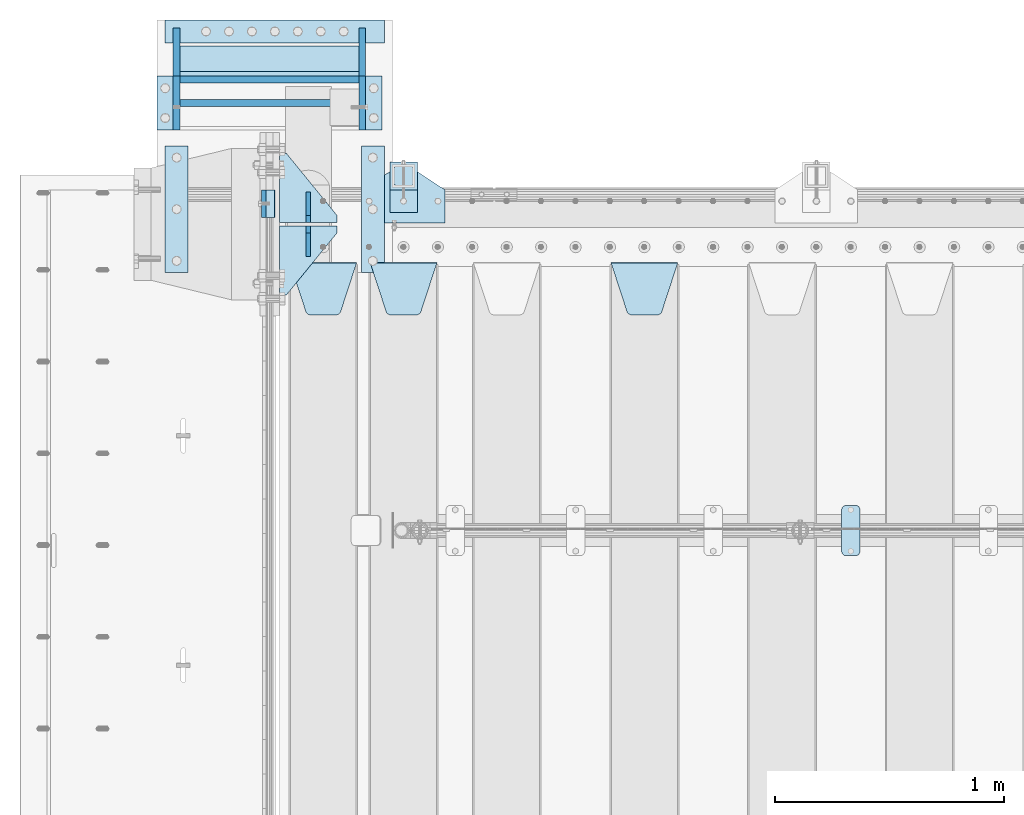
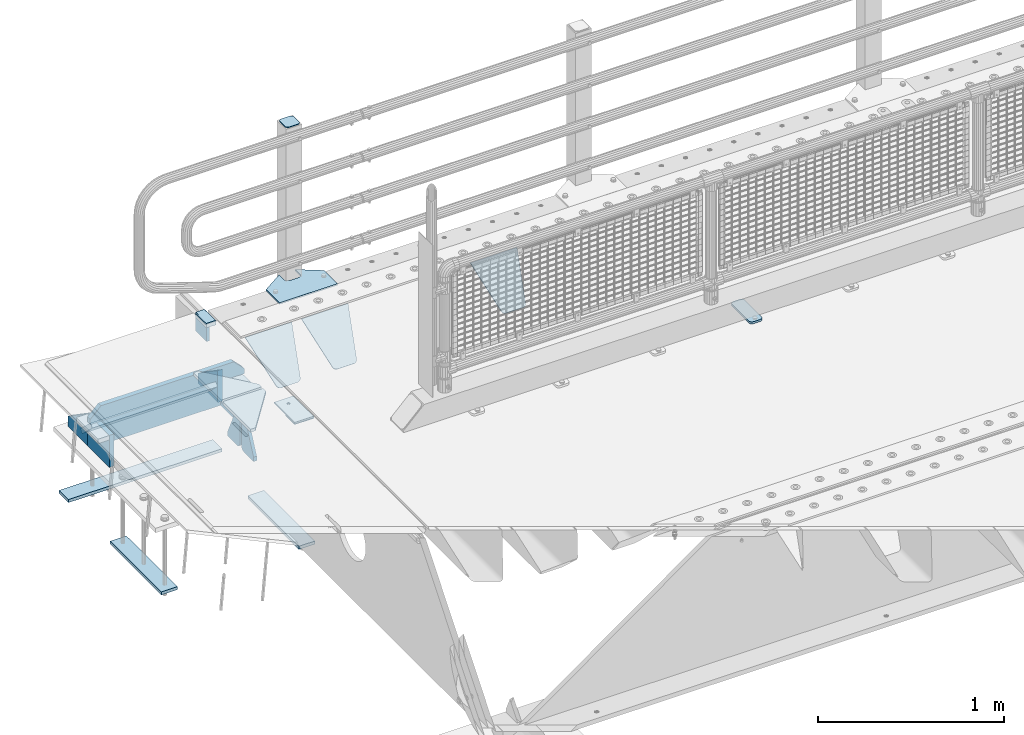
# One storey, part 159 of 193: 26 plates.
"""IFC2X3 building model written with IfcOpenShell, lengths in millimetres."""

from ifc_helpers import new_model, si_unit, frame, origin_with_axes, place, context, subcontext, project, spatial, faceted_brep, material, type_object, element, save


model = new_model("IFC2X3")

# Units and contexts
model_context = context("Model", 3, precision=1e-05, world=origin_with_axes())
body_context = subcontext(model_context, "Body", "Model", "MODEL_VIEW")
ifc_project = project(units=[si_unit("LENGTHUNIT", "METRE", prefix="MILLI"), si_unit("AREAUNIT", "SQUARE_METRE"), si_unit("VOLUMEUNIT", "CUBIC_METRE"), si_unit("MASSUNIT", "GRAM", prefix="KILO"), si_unit("TIMEUNIT", "SECOND"), si_unit("PLANEANGLEUNIT", "RADIAN"), si_unit("SOLIDANGLEUNIT", "STERADIAN"), si_unit("THERMODYNAMICTEMPERATUREUNIT", "DEGREE_CELSIUS"), si_unit("LUMINOUSINTENSITYUNIT", "LUMEN")], contexts=[model_context])

# Site, building, storey
site_placement = place(None, origin_with_axes())
site = spatial("IfcSite", under=ifc_project, at=site_placement, CompositionType="ELEMENT")
building_placement = place(site_placement, origin_with_axes())
building = spatial("IfcBuilding", under=site, at=building_placement, Name="Standard", CompositionType="ELEMENT")
storey_placement = place(building_placement, origin_with_axes())
storey = spatial("IfcBuildingStorey", under=building, at=storey_placement, Name="Undefined", CompositionType="ELEMENT", Elevation=0.0)

# Plates
ifc_material_1 = material()
plate_type_1 = type_object("IfcPlateType", PredefinedType="NOTDEFINED")
plate_1_placement = place(storey_placement, frame((-42460.0, 30090.0, -16.0000571414005), z_axis=(-1.0, 0.0, 0.0), x_axis=(0.0, 0.0, 1.0)))
element("IfcPlate", 1, at=plate_1_placement, inside=storey, type_object=plate_type_1, material=ifc_material_1, context=body_context, shape_type="Brep", body=[
    faceted_brep([(3.5527136788005e-15, -60.0, 0.0), (2.49929144047201e-09, -60.0, 60.0), (2.49929144047201e-09, 60.0000000000036, 60.0), (0.0, 60.0, -7.27595761418343e-12), (25.0146748218828, -60.0, 60.0), (25.0146748218828, 60.0, 60.0), (26.5597449794466, -60.0, 59.7552873949098), (26.5597449794466, 60.0000000000036, 59.7552873949098), (27.9535758796897, -59.9999999999964, 59.0451032832789), (27.9535758796897, 60.0000000000036, 59.0451032832789), (29.0597323263517, -60.0, 57.9389640667287), (29.0597323263517, 60.0, 57.9389640667287), (29.7699381491534, -60.0, 56.5451442289705), (29.7699381491534, 60.0, 56.5451442289705), (30.0146748212763, -60.0, 55.0000778834001), (30.0146748212763, 60.0, 55.0000778834001), (30.0154536553013, -59.9999999999964, 5.00007788340736), (30.0154536553013, 60.0000000000036, 5.00007788340736), (29.7707554908505, -60.0, 3.45497428546514), (29.7707554908505, 60.0, 3.45497428546514), (29.0605660948355, -60.0, 2.06111154406972), (29.0605660948355, 60.0, 2.06111154406972), (27.9544051209123, -59.9999999999964, 0.954933339693525), (27.9544051209123, 60.0000000000036, 0.954933339693525), (26.5605534420796, -60.0, 0.244722232011554), (26.5605534420796, 60.0, 0.244722232011554), (25.0154536559091, -60.0, 7.27595761418343e-12), (25.0154536559091, 60.0, 7.27595761418343e-12)], [[[0, 1, 2, 3]], [[1, 4, 5, 2]], [[4, 6, 7, 5]], [[6, 8, 9, 7]], [[8, 10, 11, 9]], [[10, 12, 13, 11]], [[12, 14, 15, 13]], [[14, 16, 17, 15]], [[16, 18, 19, 17]], [[18, 20, 21, 19]], [[20, 22, 23, 21]], [[22, 24, 25, 23]], [[24, 26, 27, 25]], [[26, 0, 3, 27]], [[5, 7, 9, 11, 13, 15, 17, 19, 21, 23, 25, 27, 3, 2]], [[26, 24, 22, 20, 18, 16, 14, 12, 10, 8, 6, 4, 1, 0]]]),
])
ifc_material_2 = material(Name="STEEL/S355N")
plate_type_2 = type_object("IfcPlateType", PredefinedType="NOTDEFINED")
plate_2_placement = place(storey_placement, frame((-42510.0, 30150.0000855345, -105.984391680281), z_axis=(0.0, -1.0, 0.0), x_axis=(0.0, 0.0, 1.0)))
element("IfcPlate", 2, at=plate_2_placement, inside=storey, type_object=plate_type_2, material=ifc_material_2, context=body_context, shape_type="Brep", body=[
    faceted_brep([(0.0, -10.0, 0.0), (5.70725632087488e-07, -10.0, 120.0), (5.70725632087488e-07, 10.0, 120.0), (0.0, 10.0, 0.0), (89.9845046997066, -10.0, 120.000000000004), (89.9845046997066, 10.0, 120.000000000004), (89.9843902587891, -10.0, 6.54836185276508e-11), (89.9843902587891, 10.0, 6.54836185276508e-11)], [[[0, 1, 2, 3]], [[1, 4, 5, 2]], [[4, 6, 7, 5]], [[6, 0, 3, 7]], [[5, 7, 3, 2]], [[6, 4, 1, 0]]]),
])
plate_type_3 = type_object("IfcPlateType", PredefinedType="NOTDEFINED")
plate_3_placement = place(storey_placement, frame((-40995.0, 29831.767766956, -1.76776695296758), z_axis=(0.0, -0.707106781186547, -0.707106781186548), x_axis=(1.0, 0.0, 0.0)))
element("IfcPlate", 3, at=plate_3_placement, inside=storey, type_object=plate_type_3, material=ifc_material_2, context=body_context, shape_type="Brep", body=[
    faceted_brep([(0.0, -2.5, 0.0), (69.345504679477, -2.50000000000364, 300.171731424831), (69.345504679477, 2.49999999999636, 300.171731424831), (0.0, 2.5, 0.0), (70.9274061199576, -2.50000000000364, 304.897442415397), (70.9274061199576, 2.49999999999636, 304.897442415397), (73.3818627772307, -2.50000000000364, 309.234538108529), (73.3818627772307, 2.49999999999636, 309.234538108529), (76.6187032999551, -2.50000000000728, 313.023683126103), (76.6187032999551, 2.49999999999636, 313.023683126103), (80.5190132704993, -2.50000000000364, 316.125672595372), (80.5190132704993, 2.49999999999636, 316.125672595368), (84.9395038596849, -2.50000000000364, 318.426546230472), (84.9395038596849, 2.49999999999636, 318.426546230476), (89.7177759439219, -2.50000000000364, 319.841774983273), (89.7177759439219, 2.49999999999636, 319.841774983277), (94.678286292652, -2.50000000000364, 320.319366455074), (94.678286292652, 2.49999999999636, 320.319366455074), (195.321713707348, -2.50000000000364, 320.319366455074), (195.321713707348, 2.49999999999636, 320.319366455074), (200.282224056078, -2.50000000000364, 319.841774983273), (200.282224056078, 2.49999999999636, 319.841774983277), (205.060496140315, -2.50000000000364, 318.426546230472), (205.060496140315, 2.49999999999636, 318.426546230472), (209.480986729501, -2.50000000000364, 316.125672595372), (209.480986729501, 2.49999999999636, 316.125672595368), (213.381296700045, -2.50000000000728, 313.023683126103), (213.381296700045, 2.49999999999272, 313.023683126103), (216.618137222769, -2.50000000000364, 309.234538108525), (216.618137222769, 2.49999999999636, 309.234538108522), (219.072593880042, -2.50000000000364, 304.897442415397), (219.072593880042, 2.49999999999636, 304.897442415397), (220.654495320523, -2.50000000000364, 300.171731424831), (220.654495320523, 2.49999999999636, 300.171731424831), (290.0, -2.50000000000364, 0.0), (290.0, 2.49999999999636, 0.0)], [[[0, 1, 2, 3]], [[1, 4, 5, 2]], [[4, 6, 7, 5]], [[6, 8, 9, 7]], [[8, 10, 11, 9]], [[10, 12, 13, 11]], [[12, 14, 15, 13]], [[14, 16, 17, 15]], [[16, 18, 19, 17]], [[18, 20, 21, 19]], [[20, 22, 23, 21]], [[22, 24, 25, 23]], [[24, 26, 27, 25]], [[26, 28, 29, 27]], [[28, 30, 31, 29]], [[30, 32, 33, 31]], [[32, 34, 35, 33]], [[34, 0, 3, 35]], [[5, 7, 9, 11, 13, 15, 17, 19, 21, 23, 25, 27, 29, 31, 33, 35, 3, 2]], [[34, 32, 30, 28, 26, 24, 22, 20, 18, 16, 14, 12, 10, 8, 6, 4, 1, 0]]]),
])
plate_4_placement = place(storey_placement, frame((-42045.0, 29831.767766956, -1.76776695296758), z_axis=(0.0, -0.707106781186547, -0.707106781186548), x_axis=(1.0, 0.0, 0.0)))
element("IfcPlate", 4, at=plate_4_placement, inside=storey, type_object=plate_type_3, material=ifc_material_2, context=body_context, shape_type="Brep", body=[
    faceted_brep([(0.0, -2.5, 0.0), (69.345504679477, -2.50000000000364, 300.171731424831), (69.345504679477, 2.49999999999636, 300.171731424831), (0.0, 2.5, 0.0), (70.9274061199576, -2.50000000000364, 304.897442415397), (70.9274061199576, 2.49999999999636, 304.897442415397), (73.3818627772307, -2.50000000000364, 309.234538108529), (73.3818627772307, 2.49999999999636, 309.234538108529), (76.6187032999551, -2.50000000000728, 313.023683126103), (76.6187032999551, 2.49999999999636, 313.023683126103), (80.5190132704993, -2.50000000000364, 316.125672595372), (80.5190132704993, 2.49999999999636, 316.125672595368), (84.9395038596849, -2.50000000000364, 318.426546230472), (84.9395038596849, 2.49999999999636, 318.426546230476), (89.7177759439219, -2.50000000000364, 319.841774983273), (89.7177759439219, 2.49999999999636, 319.841774983277), (94.678286292652, -2.50000000000364, 320.319366455074), (94.678286292652, 2.49999999999636, 320.319366455074), (195.321713707348, -2.50000000000364, 320.319366455074), (195.321713707348, 2.49999999999636, 320.319366455074), (200.282224056078, -2.50000000000364, 319.841774983273), (200.282224056078, 2.49999999999636, 319.841774983277), (205.060496140315, -2.50000000000364, 318.426546230472), (205.060496140315, 2.49999999999636, 318.426546230472), (209.480986729501, -2.50000000000364, 316.125672595372), (209.480986729501, 2.49999999999636, 316.125672595368), (213.381296700045, -2.50000000000728, 313.023683126103), (213.381296700045, 2.49999999999272, 313.023683126103), (216.618137222769, -2.50000000000364, 309.234538108525), (216.618137222769, 2.49999999999636, 309.234538108522), (219.072593880042, -2.50000000000364, 304.897442415397), (219.072593880042, 2.49999999999636, 304.897442415397), (220.654495320523, -2.50000000000364, 300.171731424831), (220.654495320523, 2.49999999999636, 300.171731424831), (290.0, -2.50000000000364, 0.0), (290.0, 2.49999999999636, 0.0)], [[[0, 1, 2, 3]], [[1, 4, 5, 2]], [[4, 6, 7, 5]], [[6, 8, 9, 7]], [[8, 10, 11, 9]], [[10, 12, 13, 11]], [[12, 14, 15, 13]], [[14, 16, 17, 15]], [[16, 18, 19, 17]], [[18, 20, 21, 19]], [[20, 22, 23, 21]], [[22, 24, 25, 23]], [[24, 26, 27, 25]], [[26, 28, 29, 27]], [[28, 30, 31, 29]], [[30, 32, 33, 31]], [[32, 34, 35, 33]], [[34, 0, 3, 35]], [[5, 7, 9, 11, 13, 15, 17, 19, 21, 23, 25, 27, 29, 31, 33, 35, 3, 2]], [[34, 32, 30, 28, 26, 24, 22, 20, 18, 16, 14, 12, 10, 8, 6, 4, 1, 0]]]),
])
plate_5_placement = place(storey_placement, frame((-42395.0, 29831.767766956, -1.76776695296758), z_axis=(0.0, -0.707106781186547, -0.707106781186548), x_axis=(1.0, 0.0, 0.0)))
element("IfcPlate", 5, at=plate_5_placement, inside=storey, type_object=plate_type_3, material=ifc_material_2, context=body_context, shape_type="Brep", body=[
    faceted_brep([(0.0, -2.5, 0.0), (69.345504679477, -2.50000000000364, 300.171731424831), (69.345504679477, 2.49999999999636, 300.171731424831), (0.0, 2.5, 0.0), (70.9274061199576, -2.50000000000364, 304.897442415397), (70.9274061199576, 2.49999999999636, 304.897442415397), (73.3818627772307, -2.50000000000364, 309.234538108529), (73.3818627772307, 2.49999999999636, 309.234538108529), (76.6187032999551, -2.50000000000728, 313.023683126103), (76.6187032999551, 2.49999999999636, 313.023683126103), (80.5190132704993, -2.50000000000364, 316.125672595372), (80.5190132704993, 2.49999999999636, 316.125672595368), (84.9395038596849, -2.50000000000364, 318.426546230472), (84.9395038596849, 2.49999999999636, 318.426546230476), (89.7177759439219, -2.50000000000364, 319.841774983273), (89.7177759439219, 2.49999999999636, 319.841774983277), (94.678286292652, -2.50000000000364, 320.319366455074), (94.678286292652, 2.49999999999636, 320.319366455074), (195.321713707348, -2.50000000000364, 320.319366455074), (195.321713707348, 2.49999999999636, 320.319366455074), (200.282224056078, -2.50000000000364, 319.841774983273), (200.282224056078, 2.49999999999636, 319.841774983277), (205.060496140315, -2.50000000000364, 318.426546230472), (205.060496140315, 2.49999999999636, 318.426546230472), (209.480986729501, -2.50000000000364, 316.125672595372), (209.480986729501, 2.49999999999636, 316.125672595368), (213.381296700045, -2.50000000000728, 313.023683126103), (213.381296700045, 2.49999999999272, 313.023683126103), (216.618137222769, -2.50000000000364, 309.234538108525), (216.618137222769, 2.49999999999636, 309.234538108522), (219.072593880042, -2.50000000000364, 304.897442415397), (219.072593880042, 2.49999999999636, 304.897442415397), (220.654495320523, -2.50000000000364, 300.171731424831), (220.654495320523, 2.49999999999636, 300.171731424831), (290.0, -2.50000000000364, 0.0), (290.0, 2.49999999999636, 0.0)], [[[0, 1, 2, 3]], [[1, 4, 5, 2]], [[4, 6, 7, 5]], [[6, 8, 9, 7]], [[8, 10, 11, 9]], [[10, 12, 13, 11]], [[12, 14, 15, 13]], [[14, 16, 17, 15]], [[16, 18, 19, 17]], [[18, 20, 21, 19]], [[20, 22, 23, 21]], [[22, 24, 25, 23]], [[24, 26, 27, 25]], [[26, 28, 29, 27]], [[28, 30, 31, 29]], [[30, 32, 33, 31]], [[32, 34, 35, 33]], [[34, 0, 3, 35]], [[5, 7, 9, 11, 13, 15, 17, 19, 21, 23, 25, 27, 29, 31, 33, 35, 3, 2]], [[34, 32, 30, 28, 26, 24, 22, 20, 18, 16, 14, 12, 10, 8, 6, 4, 1, 0]]]),
])
plate_type_4 = type_object("IfcPlateType", PredefinedType="NOTDEFINED")
for number, where, z_axis, x_axis in (
    (6, (-42190.0, 30008.0, -515.0), (0.0, 1.0, 0.0), (-1.0, 0.0, 0.0)),
    (7, (-42190.0, 29992.0, -515.0), (0.0, -1.0, 0.0), (-1.0, 0.0, 0.0)),
):
    element("IfcPlate", number, at=place(storey_placement, frame(where, z_axis=z_axis, x_axis=x_axis)), inside=storey, type_object=plate_type_4, material=ifc_material_2, context=body_context, shape_type="Brep", body=[
        faceted_brep([(0.0, -10.0, 0.0), (0.0, -10.0, 30.0), (0.0, 10.0, 30.0), (0.0, 10.0, 0.0), (220.0, -10.0, 300.0), (220.0, 10.0, 300.0), (250.0, -10.0, 300.0), (250.0, 10.0, 300.0), (250.0, -10.0, 0.0), (250.0, 10.0, 0.0)], [[[0, 1, 2, 3]], [[1, 4, 5, 2]], [[4, 6, 7, 5]], [[6, 8, 9, 7]], [[8, 0, 3, 9]], [[5, 7, 9, 3, 2]], [[8, 6, 4, 1, 0]]]),
    ])
plate_type_5 = type_object("IfcPlateType", PredefinedType="NOTDEFINED")
for number, where, z_axis, x_axis in (
    (8, (-42315.0, 29860.0, -860.0), (0.0, 0.0, 1.0), (0.0, 1.0, 0.0)),
    (9, (-42315.0, 30140.0, -860.0), (0.0, 0.0, 1.0), (0.0, -1.0, 0.0)),
):
    element("IfcPlate", number, at=place(storey_placement, frame(where, z_axis=z_axis, x_axis=x_axis)), inside=storey, type_object=plate_type_5, material=ifc_material_2, context=body_context, shape_type="Brep", body=[
        faceted_brep([(0.0, -10.0, 0.0), (0.0, -10.0, 30.0), (0.0, 10.0, 30.0), (0.0, 10.0, 0.0), (102.0, -10.0, 250.0), (102.0, 10.0, 250.0), (132.0, -10.0, 250.0), (132.0, 10.0, 250.0), (132.0, -10.0, 30.0), (132.0, 10.0, 30.0), (131.544232590368, -10.0, 24.790554669992), (131.544232590368, 10.0, 24.790554669992), (130.190778623579, -10.0, 19.7393957002299), (130.190778623579, 10.0, 19.7393957002299), (127.980762113533, -10.0, 15.0), (127.980762113533, 10.0, 15.0), (124.98133329357, -10.0, 10.7163717094038), (124.98133329357, 10.0, 10.7163717094038), (121.283628290596, -10.0, 7.01866670643062), (121.283628290596, 10.0, 7.01866670643062), (117.0, -10.0, 4.01923788646684), (117.0, 10.0, 4.01923788646684), (112.260604299769, -10.0, 1.80922137642278), (112.260604299769, 10.0, 1.80922137642278), (107.209445330009, -10.0, 0.455767409633722), (107.209445330009, 10.0, 0.455767409633722), (102.0, -10.0, 0.0), (102.0, 10.0, 0.0)], [[[0, 1, 2, 3]], [[1, 4, 5, 2]], [[4, 6, 7, 5]], [[6, 8, 9, 7]], [[8, 10, 11, 9]], [[10, 12, 13, 11]], [[12, 14, 15, 13]], [[14, 16, 17, 15]], [[16, 18, 19, 17]], [[18, 20, 21, 19]], [[20, 22, 23, 21]], [[22, 24, 25, 23]], [[24, 26, 27, 25]], [[26, 0, 3, 27]], [[5, 7, 9, 11, 13, 15, 17, 19, 21, 23, 25, 27, 3, 2]], [[26, 24, 22, 20, 18, 16, 14, 12, 10, 8, 6, 4, 1, 0]]]),
    ])
ifc_material_3 = material(Name="STEEL/S355J2")
plate_type_6 = type_object("IfcPlateType", PredefinedType="NOTDEFINED")
plate_6_placement = place(storey_placement, frame((-42080.0, 30005.0, 5.00000000004911), z_axis=(0.0, 1.0, 0.0), x_axis=(1.0, 0.0, 0.0)))
element("IfcPlate", 10, at=plate_6_placement, inside=storey, type_object=plate_type_6, material=ifc_material_3, context=body_context, shape_type="Brep", body=[
    faceted_brep([(0.0, -5.0, 0.0), (2.31396552408114e-06, -5.0, 145.0), (2.31396552408114e-06, 5.0, 145.0), (0.0, 5.0, 0.0), (130.0, -5.0, 230.0), (130.0, 5.0, 230.0), (130.0, -5.0, 180.0), (130.0, 5.0, 180.0), (130.48036798992, -5.0, 175.122741949595), (130.48036798992, 5.0, 175.122741949595), (131.903011687216, -5.0, 170.432914190871), (131.903011687216, 5.0, 170.432914190871), (134.213259692435, -5.0, 166.110744174512), (134.213259692435, 5.0, 166.110744174512), (137.322330470335, -5.0, 162.322330470335), (137.322330470335, 5.0, 162.322330470335), (141.110744174512, -5.0, 159.213259692435), (141.110744174512, 5.0, 159.213259692435), (145.432914190871, -5.0, 156.903011687216), (145.432914190871, 5.0, 156.903011687216), (150.122741949595, -5.0, 155.48036798992), (150.122741949595, 5.0, 155.48036798992), (155.0, -5.0, 155.0), (155.0, 5.0, 155.0), (205.0, -5.0, 155.0), (205.0, 5.0, 155.0), (209.877258050405, -5.0, 155.48036798992), (209.877258050405, 5.0, 155.48036798992), (214.567085809129, -5.0, 156.903011687216), (214.567085809129, 5.0, 156.903011687216), (218.889255825488, -5.0, 159.213259692435), (218.889255825488, 5.0, 159.213259692435), (222.677669529665, -5.0, 162.322330470335), (222.677669529665, 5.0, 162.322330470335), (225.786740307565, -5.0, 166.110744174512), (225.786740307565, 5.0, 166.110744174512), (228.096988312784, -5.0, 170.432914190871), (228.096988312784, 5.0, 170.432914190871), (229.51963201008, -5.0, 175.122741949595), (229.51963201008, 5.0, 175.122741949595), (230.0, -5.0, 180.0), (230.0, 5.0, 180.0), (230.0, -5.0, 230.0), (230.0, 5.0, 230.0), (360.0, -5.0, 145.0), (360.0, 5.0, 145.0), (360.0, -5.0, -7.27595761418343e-12), (360.0, 5.0, -7.27595761418343e-12)], [[[0, 1, 2, 3]], [[1, 4, 5, 2]], [[4, 6, 7, 5]], [[6, 8, 9, 7]], [[8, 10, 11, 9]], [[10, 12, 13, 11]], [[12, 14, 15, 13]], [[14, 16, 17, 15]], [[16, 18, 19, 17]], [[18, 20, 21, 19]], [[20, 22, 23, 21]], [[22, 24, 25, 23]], [[24, 26, 27, 25]], [[26, 28, 29, 27]], [[28, 30, 31, 29]], [[30, 32, 33, 31]], [[32, 34, 35, 33]], [[34, 36, 37, 35]], [[36, 38, 39, 37]], [[38, 40, 41, 39]], [[40, 42, 43, 41]], [[42, 44, 45, 43]], [[44, 46, 47, 45]], [[46, 0, 3, 47]], [[5, 7, 9, 11, 13, 15, 17, 19, 21, 23, 25, 27, 29, 31, 33, 35, 37, 39, 41, 43, 45, 47, 3, 2]], [[46, 44, 42, 40, 38, 36, 34, 32, 30, 28, 26, 24, 22, 20, 18, 16, 14, 12, 10, 8, 6, 4, 1, 0]]]),
])
plate_type_7 = type_object("IfcPlateType", PredefinedType="NOTDEFINED")
plate_7_placement = place(storey_placement, frame((-41959.9999999999, 30050.0000000002, -850.000000000002), z_axis=(0.0, 1.0, 0.0), x_axis=(1.0, 0.0, 0.0)))
element("IfcPlate", 11, at=plate_7_placement, inside=storey, type_object=plate_type_7, material=ifc_material_3, context=body_context, shape_type="Brep", body=[
    faceted_brep([(66.3639610305399, -5.0, 163.636038969111), (66.3639610305399, 5.0, 163.636038969111), (59.9999999998618, 5.0, 160.999999999789), (59.9999999998618, -5.0, 160.999999999789), (53.6360389691836, 5.0, 163.636038969111), (53.6360389691836, -5.0, 163.636038969111), (50.9999999998618, 5.0, 169.999999999789), (50.9999999998618, -5.0, 169.999999999789), (53.6360389691836, 5.0, 176.363961030467), (53.6360389691836, -5.0, 176.363961030467), (59.9999999998618, 5.0, 178.999999999789), (59.9999999998618, -5.0, 178.999999999789), (66.3639610305399, 5.0, 176.363961030467), (66.3639610305399, -5.0, 176.363961030467), (68.9999999998618, 5.0, 169.999999999789), (68.9999999998618, -5.0, 169.999999999789), (120.0, -5.0, 0.0), (120.0, -5.0, 220.0), (0.0, -5.0, 220.0), (0.0, -5.0, 0.0), (0.0, 5.0, 0.0), (120.0, 5.0, 0.0), (120.0, 5.0, 220.0), (0.0, 5.0, 220.0)], [[[0, 1, 2, 3]], [[3, 2, 4, 5]], [[5, 4, 6, 7]], [[7, 6, 8, 9]], [[9, 8, 10, 11]], [[11, 10, 12, 13]], [[13, 12, 14, 15]], [[15, 14, 1, 0]], [[16, 17, 18, 19], [3, 5, 7, 9, 11, 13, 15, 0]], [[16, 19, 20, 21]], [[17, 16, 21, 22]], [[18, 17, 22, 23]], [[19, 18, 23, 20]], [[22, 21, 20, 23], [10, 8, 6, 4, 2, 1, 14, 12]]]),
])
plate_type_8 = type_object("IfcPlateType", PredefinedType="NOTDEFINED")
plate_8_placement = place(storey_placement, frame((-41855.9999999999, 30166.0000000002, 1012.50000000001), z_axis=(0.0, 1.0, 0.0), x_axis=(-1.0, 0.0, 0.0)))
element("IfcPlate", 12, at=plate_8_placement, inside=storey, type_object=plate_type_8, material=ifc_material_3, context=body_context, shape_type="Brep", body=[
    faceted_brep([(0.0, -2.5, 19.0), (0.0, -2.5, 69.0), (0.0, 2.5, 69.0), (0.0, 2.5, 19.0), (0.476369668544066, -2.5, 73.2278977451715), (0.476369668544066, 2.5, 73.2278977451715), (1.88159150985302, -2.5, 77.2437910432345), (1.88159150985302, 2.5, 77.2437910432345), (4.14520183310742, -2.5, 80.8463062353148), (4.14520183310742, 2.5, 80.8463062353148), (7.15369376468516, -2.5, 83.8547981668926), (7.15369376468516, 2.5, 83.8547981668926), (10.7562089567655, -2.5, 86.118408490147), (10.7562089567655, 2.5, 86.118408490147), (14.7721022548285, -2.5, 87.5236303314559), (14.7721022548285, 2.5, 87.5236303314559), (19.0, -2.5, 88.0), (19.0, 2.5, 88.0), (69.0, -2.5, 88.0), (69.0, 2.5, 88.0), (73.2278977451715, -2.5, 87.5236303314559), (73.2278977451715, 2.5, 87.5236303314559), (77.2437910432345, -2.5, 86.118408490147), (77.2437910432345, 2.5, 86.118408490147), (80.8463062353148, -2.5, 83.8547981668926), (80.8463062353148, 2.5, 83.8547981668926), (83.8547981668926, -2.5, 80.8463062353148), (83.8547981668926, 2.5, 80.8463062353148), (86.118408490147, -2.5, 77.2437910432345), (86.118408490147, 2.5, 77.2437910432345), (87.5236303314559, -2.5, 73.2278977451715), (87.5236303314559, 2.5, 73.2278977451715), (88.0, -2.5, 69.0), (88.0, 2.5, 69.0), (88.0, -2.5, 19.0), (88.0, 2.5, 19.0), (87.5236303314559, -2.5, 14.7721022548285), (87.5236303314559, 2.5, 14.7721022548285), (86.118408490147, -2.5, 10.7562089567655), (86.118408490147, 2.5, 10.7562089567655), (83.8547981668926, -2.5, 7.15369376468516), (83.8547981668926, 2.5, 7.15369376468516), (80.8463062353148, -2.5, 4.14520183310742), (80.8463062353148, 2.5, 4.14520183310742), (77.2437910432345, -2.5, 1.88159150985302), (77.2437910432345, 2.5, 1.88159150985302), (73.2278977451715, -2.5, 0.476369668544066), (73.2278977451715, 2.5, 0.476369668544066), (69.0, -2.5, 0.0), (69.0, 2.5, 0.0), (19.0, -2.5, 0.0), (19.0, 2.5, 0.0), (14.7721022548285, -2.5, 0.476369668544066), (14.7721022548285, 2.5, 0.476369668544066), (10.7562089567655, -2.5, 1.88159150985302), (10.7562089567655, 2.5, 1.88159150985302), (7.15369376468516, -2.5, 4.14520183310742), (7.15369376468516, 2.5, 4.14520183310742), (4.14520183310742, -2.5, 7.15369376468516), (4.14520183310742, 2.5, 7.15369376468516), (1.88159150985302, -2.5, 10.7562089567655), (1.88159150985302, 2.5, 10.7562089567655), (0.476369668544066, -2.5, 14.7721022548285), (0.476369668544066, 2.5, 14.7721022548285)], [[[0, 1, 2, 3]], [[1, 4, 5, 2]], [[4, 6, 7, 5]], [[6, 8, 9, 7]], [[8, 10, 11, 9]], [[10, 12, 13, 11]], [[12, 14, 15, 13]], [[14, 16, 17, 15]], [[16, 18, 19, 17]], [[18, 20, 21, 19]], [[20, 22, 23, 21]], [[22, 24, 25, 23]], [[24, 26, 27, 25]], [[26, 28, 29, 27]], [[28, 30, 31, 29]], [[30, 32, 33, 31]], [[32, 34, 35, 33]], [[34, 36, 37, 35]], [[36, 38, 39, 37]], [[38, 40, 41, 39]], [[40, 42, 43, 41]], [[42, 44, 45, 43]], [[44, 46, 47, 45]], [[46, 48, 49, 47]], [[48, 50, 51, 49]], [[50, 52, 53, 51]], [[52, 54, 55, 53]], [[54, 56, 57, 55]], [[56, 58, 59, 57]], [[58, 60, 61, 59]], [[60, 62, 63, 61]], [[62, 0, 3, 63]], [[5, 7, 9, 11, 13, 15, 17, 19, 21, 23, 25, 27, 29, 31, 33, 35, 37, 39, 41, 43, 45, 47, 49, 51, 53, 55, 57, 59, 61, 63, 3, 2]], [[62, 60, 58, 56, 54, 52, 50, 48, 46, 44, 42, 40, 38, 36, 34, 32, 30, 28, 26, 24, 22, 20, 18, 16, 14, 12, 10, 8, 6, 4, 1, 0]]]),
])
plate_type_9 = type_object("IfcPlateType", PredefinedType="NOTDEFINED")
plate_9_placement = place(storey_placement, frame((-41959.9999999999, 30050.0000000002, -857.500000000002), z_axis=(0.0, 1.0, 0.0), x_axis=(1.0, 0.0, 0.0)))
element("IfcPlate", 13, at=plate_9_placement, inside=storey, type_object=plate_type_9, material=ifc_material_3, context=body_context, shape_type="Brep", body=[
    faceted_brep([(0.0, -2.5, 0.0), (0.0, -2.5, 100.0), (0.0, 2.5, 100.0), (0.0, 2.5, 0.0), (120.0, -2.5, 100.0), (120.0, 2.5, 100.0), (120.0, -2.5, 0.0), (120.0, 2.5, 0.0)], [[[0, 1, 2, 3]], [[1, 4, 5, 2]], [[4, 6, 7, 5]], [[6, 0, 3, 7]], [[5, 7, 3, 2]], [[6, 4, 1, 0]]]),
])
plate_type_10 = type_object("IfcPlateType", PredefinedType="NOTDEFINED")
plate_10_placement = place(storey_placement, frame((-42095.0, 30765.3571347532, -1017.14966545659), z_axis=(-1.0, 0.0, 0.0), x_axis=(0.0, -0.723355636225729, 0.690475650215467)))
element("IfcPlate", 14, at=plate_10_placement, inside=storey, type_object=plate_type_10, material=ifc_material_2, context=body_context, shape_type="Brep", body=[
    faceted_brep([(0.0, -15.0, 0.0), (-3.63797880709171e-12, -14.9999999999964, 779.0), (-3.63797880709171e-12, 15.0, 779.0), (0.0, 15.0, 0.0), (152.069061279297, -15.0, 779.0), (152.069061279293, 15.0, 779.0), (152.069061279297, -15.0, 0.0), (152.069061279293, 15.0, 0.0)], [[[0, 1, 2, 3]], [[1, 4, 5, 2]], [[4, 6, 7, 5]], [[6, 0, 3, 7]], [[5, 7, 3, 2]], [[6, 4, 1, 0]]]),
])
plate_type_11 = type_object("IfcPlateType", PredefinedType="NOTDEFINED")
for number, where, z_axis, x_axis in (
    (15, (-42939.0, 30339.9999985338, -1468.0), (0.0, -1.0, 0.0), (1.0, 0.0, 0.0)),
    (16, (-42084.0, 30339.9999985338, -1468.0), (0.0, -1.0, 0.0), (1.0, 0.0, 0.0)),
):
    element("IfcPlate", number, at=place(storey_placement, frame(where, z_axis=z_axis, x_axis=x_axis)), inside=storey, type_object=plate_type_11, material=ifc_material_2, context=body_context, shape_type="Brep", body=[
        faceted_brep([(0.0, -10.0, 0.0), (1.00942997960374e-06, -10.0, 550.0), (1.00942997960374e-06, 10.0, 550.0), (0.0, 10.0, 0.0), (100.0, -10.0, 550.0), (100.0, 10.0, 550.0), (100.0, -10.0, 0.0), (100.0, 10.0, 0.0)], [[[0, 1, 2, 3]], [[1, 4, 5, 2]], [[4, 6, 7, 5]], [[6, 0, 3, 7]], [[5, 7, 3, 2]], [[6, 4, 1, 0]]]),
    ])
plate_11_placement = place(storey_placement, frame((-42939.0, 30889.9999985338, -1468.0), z_axis=(0.0, -1.0, 0.0), x_axis=(1.0, 0.0, 0.0)))
element("IfcPlate", 17, at=plate_11_placement, inside=storey, type_object=plate_type_11, material=ifc_material_2, context=body_context, shape_type="Brep", body=[
    faceted_brep([(0.0, -10.0, 0.0), (0.0, -10.0, 100.0), (0.0, 10.0, 100.0), (0.0, 10.0, 0.0), (955.0, -10.0, 100.0), (955.0, 10.0, 100.0), (955.0, -10.0, 0.0), (955.0, 10.0, 0.0)], [[[0, 1, 2, 3]], [[1, 4, 5, 2]], [[4, 6, 7, 5]], [[6, 0, 3, 7]], [[5, 7, 3, 2]], [[6, 4, 1, 0]]]),
])
plate_type_12 = type_object("IfcPlateType", PredefinedType="NOTDEFINED")
for number, where, z_axis, x_axis in (
    (18, (-42080.0, 30855.0, -1028.0), (0.0, 0.0, 1.0), (0.0, -1.0, 0.0)),
    (19, (-42889.0, 30855.0, -1028.0), (0.0, 0.0, 1.0), (0.0, -1.0, 0.0)),
):
    element("IfcPlate", number, at=place(storey_placement, frame(where, z_axis=z_axis, x_axis=x_axis)), inside=storey, type_object=plate_type_12, material=ifc_material_2, context=body_context, shape_type="Brep", body=[
        faceted_brep([(0.0, -15.0, 0.0), (0.0, -15.0, 66.0), (0.0, 15.0, 66.0), (0.0, 15.0, 0.0), (210.0, -15.0, 210.0), (210.0, 15.0, 210.0), (210.0, -15.0, 0.0), (210.0, 15.0, 0.0)], [[[0, 1, 2, 3]], [[1, 4, 5, 2]], [[4, 6, 7, 5]], [[6, 0, 3, 7]], [[5, 7, 3, 2]], [[6, 4, 1, 0]]]),
    ])
plate_12_placement = place(storey_placement, frame((-42080.0, 30410.0, -818.000000000005), z_axis=(0.0, 0.0, -1.0), x_axis=(0.0, 1.0, 0.0)))
element("IfcPlate", 20, at=plate_12_placement, inside=storey, type_object=plate_type_12, material=ifc_material_2, context=body_context, shape_type="Brep", body=[
    faceted_brep([(0.0, -15.0, 0.0), (0.0, -15.0, 210.0), (0.0, 15.0, 210.0), (0.0, 15.0, 0.0), (235.0, -15.0, 210.0), (235.0, 15.0, 210.0), (235.0, -15.0, 0.0), (235.0, 15.0, 0.0)], [[[0, 1, 2, 3]], [[1, 4, 5, 2]], [[4, 6, 7, 5]], [[6, 0, 3, 7]], [[5, 7, 3, 2]], [[6, 4, 1, 0]]]),
])
plate_13_placement = place(storey_placement, frame((-42874.0, 30630.0, -1028.0), z_axis=(1.0, 0.0, 0.0), x_axis=(0.0, 0.0, 1.0)))
element("IfcPlate", 21, at=plate_13_placement, inside=storey, type_object=plate_type_12, material=ifc_material_2, context=body_context, shape_type="Brep", body=[
    faceted_brep([(0.0, -15.0, 0.0), (-3.63797880709171e-12, -14.9999999999964, 779.0), (-3.63797880709171e-12, 15.0, 779.0), (0.0, 15.0, 0.0), (210.0, -15.0, 779.0), (210.0, 15.0, 779.0), (210.0, -15.0, 0.0), (210.0, 15.0, 0.0)], [[[0, 1, 2, 3]], [[1, 4, 5, 2]], [[4, 6, 7, 5]], [[6, 0, 3, 7]], [[5, 7, 3, 2]], [[6, 4, 1, 0]]]),
])
plate_14_placement = place(storey_placement, frame((-42889.0, 30410.0, -818.000000000004), z_axis=(0.0, 0.0, -1.0), x_axis=(0.0, 1.0, 0.0)))
element("IfcPlate", 22, at=plate_14_placement, inside=storey, type_object=plate_type_12, material=ifc_material_2, context=body_context, shape_type="Brep", body=[
    faceted_brep([(0.0, -15.0, 0.0), (0.0, -15.0, 210.0), (0.0, 15.0, 210.0), (0.0, 15.0, 0.0), (235.0, -15.0, 210.0), (235.0, 15.0, 210.0), (235.0, -15.0, 0.0), (235.0, 15.0, 0.0)], [[[0, 1, 2, 3]], [[1, 4, 5, 2]], [[4, 6, 7, 5]], [[6, 0, 3, 7]], [[5, 7, 3, 2]], [[6, 4, 1, 0]]]),
])
plate_type_13 = type_object("IfcPlateType", PredefinedType="NOTDEFINED")
plate_15_placement = place(storey_placement, frame((-42964.0, 30527.5, -788.000000000004), z_axis=(0.0, 0.0, 1.0), x_axis=(1.0, 0.0, 0.0)))
element("IfcPlate", 23, at=plate_15_placement, inside=storey, type_object=plate_type_13, material=ifc_material_2, context=body_context, shape_type="Brep", body=[
    faceted_brep([(0.0, -15.0, 0.0), (0.0, -15.0, 33.0), (0.0, 15.0, 33.0), (0.0, 15.0, 0.0), (67.0, -15.0, 100.0), (67.0, 15.0, 100.0), (892.0, -15.0, 100.0), (892.0, 15.0, 100.0), (959.0, -15.0, 33.0), (959.0, 15.0, 33.0), (959.0, -15.0, 0.0), (959.0, 15.0, 0.0)], [[[0, 1, 2, 3]], [[1, 4, 5, 2]], [[4, 6, 7, 5]], [[6, 8, 9, 7]], [[8, 10, 11, 9]], [[10, 0, 3, 11]], [[5, 7, 9, 11, 3, 2]], [[10, 8, 6, 4, 1, 0]]]),
])
plate_type_14 = type_object("IfcPlateType", PredefinedType="NOTDEFINED")
for number, where, z_axis, x_axis in (
    (24, (-42065.0, 30645.0, -833.000000000004), (1.0, 0.0, 0.0), (0.0, -1.0, 0.0)),
    (25, (-42974.0, 30645.0, -833.000000000004), (1.0, 0.0, 0.0), (0.0, -1.0, 0.0)),
):
    element("IfcPlate", number, at=place(storey_placement, frame(where, z_axis=z_axis, x_axis=x_axis)), inside=storey, type_object=plate_type_14, material=ifc_material_2, context=body_context, shape_type="Brep", body=[
        faceted_brep([(0.0, -15.0, 0.0), (0.0, -15.0, 70.0), (0.0, 15.0, 70.0), (0.0, 15.0, 0.0), (235.0, -15.0, 70.0), (235.0, 15.0, 70.0), (235.0, -15.0, 0.0), (235.0, 15.0, 0.0)], [[[0, 1, 2, 3]], [[1, 4, 5, 2]], [[4, 6, 7, 5]], [[6, 0, 3, 7]], [[5, 7, 3, 2]], [[6, 4, 1, 0]]]),
    ])
plate_type_15 = type_object("IfcPlateType", PredefinedType="NOTDEFINED")
plate_16_placement = place(storey_placement, frame((-39990.0, 28774.5, 21.0199999999977), z_axis=(1.0, 0.0, 0.0), x_axis=(0.0, -1.0, 0.0)))
element("IfcPlate", 26, at=plate_16_placement, inside=storey, type_object=plate_type_15, material=ifc_material_3, context=body_context, shape_type="Brep", body=[
    faceted_brep([(0.0, -7.0, 20.0), (0.0, -7.0, 60.0), (0.0, 7.0, 60.0), (0.0, 7.0, 20.0), (0.384294391937146, -7.0, 63.9018064403208), (0.384294391937146, 7.0, 63.9018064403208), (1.52240934977453, -7.0, 67.6536686473009), (1.52240934977453, 7.0, 67.6536686473009), (3.37060775395003, -7.0, 71.1114046603907), (3.37060775395003, 7.0, 71.1114046603907), (5.8578643762703, -7.0, 74.1421356237297), (5.8578643762703, 7.0, 74.1421356237297), (8.88859533960931, -7.0, 76.62939224605), (8.88859533960931, 7.0, 76.62939224605), (12.3463313526991, -7.0, 78.4775906502255), (12.3463313526991, 7.0, 78.4775906502255), (16.0981935596792, -7.0, 79.6157056080629), (16.0981935596792, 7.0, 79.6157056080629), (20.0, -7.0, 80.0), (20.0, 7.0, 80.0), (200.0, -7.0, 80.0), (200.0, 7.0, 80.0), (203.901806440321, -7.0, 79.6157056080629), (203.901806440321, 7.0, 79.6157056080629), (207.653668647301, -7.0, 78.4775906502255), (207.653668647301, 7.0, 78.4775906502255), (211.111404660391, -7.0, 76.62939224605), (211.111404660391, 7.0, 76.62939224605), (214.14213562373, -7.0, 74.1421356237297), (214.14213562373, 7.0, 74.1421356237297), (216.62939224605, -7.0, 71.1114046603907), (216.62939224605, 7.0, 71.1114046603907), (218.477590650225, -7.0, 67.6536686473009), (218.477590650225, 7.0, 67.6536686473009), (219.615705608063, -7.0, 63.9018064403208), (219.615705608063, 7.0, 63.9018064403208), (220.0, -7.0, 60.0), (220.0, 7.0, 60.0), (220.0, -7.0, 20.0), (220.0, 7.0, 20.0), (219.615705608063, -7.0, 16.0981935596792), (219.615705608063, 7.0, 16.0981935596792), (218.477590650225, -7.0, 12.3463313526991), (218.477590650225, 7.0, 12.3463313526991), (216.62939224605, -7.0, 8.88859533960931), (216.62939224605, 7.0, 8.88859533960931), (214.14213562373, -7.0, 5.8578643762703), (214.14213562373, 7.0, 5.8578643762703), (211.111404660391, -7.0, 3.37060775395003), (211.111404660391, 7.0, 3.37060775395003), (207.653668647301, -7.0, 1.52240934977453), (207.653668647301, 7.0, 1.52240934977453), (203.901806440321, -7.0, 0.384294391937146), (203.901806440321, 7.0, 0.384294391937146), (200.0, -7.0, 0.0), (200.0, 7.0, 0.0), (20.0, -7.0, 0.0), (20.0, 7.0, 0.0), (16.0981935596792, -7.0, 0.384294391937146), (16.0981935596792, 7.0, 0.384294391937146), (12.3463313526991, -7.0, 1.52240934977453), (12.3463313526991, 7.0, 1.52240934977453), (8.88859533960931, -7.0, 3.37060775395003), (8.88859533960931, 7.0, 3.37060775395003), (5.8578643762703, -7.0, 5.8578643762703), (5.8578643762703, 7.0, 5.8578643762703), (3.37060775395003, -7.0, 8.88859533960931), (3.37060775395003, 7.0, 8.88859533960931), (1.52240934977453, -7.0, 12.3463313526991), (1.52240934977453, 7.0, 12.3463313526991), (0.384294391937146, -7.0, 16.0981935596792), (0.384294391937146, 7.0, 16.0981935596792)], [[[0, 1, 2, 3]], [[1, 4, 5, 2]], [[4, 6, 7, 5]], [[6, 8, 9, 7]], [[8, 10, 11, 9]], [[10, 12, 13, 11]], [[12, 14, 15, 13]], [[14, 16, 17, 15]], [[16, 18, 19, 17]], [[18, 20, 21, 19]], [[20, 22, 23, 21]], [[22, 24, 25, 23]], [[24, 26, 27, 25]], [[26, 28, 29, 27]], [[28, 30, 31, 29]], [[30, 32, 33, 31]], [[32, 34, 35, 33]], [[34, 36, 37, 35]], [[36, 38, 39, 37]], [[38, 40, 41, 39]], [[40, 42, 43, 41]], [[42, 44, 45, 43]], [[44, 46, 47, 45]], [[46, 48, 49, 47]], [[48, 50, 51, 49]], [[50, 52, 53, 51]], [[52, 54, 55, 53]], [[54, 56, 57, 55]], [[56, 58, 59, 57]], [[58, 60, 61, 59]], [[60, 62, 63, 61]], [[62, 64, 65, 63]], [[64, 66, 67, 65]], [[66, 68, 69, 67]], [[68, 70, 71, 69]], [[70, 0, 3, 71]], [[5, 7, 9, 11, 13, 15, 17, 19, 21, 23, 25, 27, 29, 31, 33, 35, 37, 39, 41, 43, 45, 47, 49, 51, 53, 55, 57, 59, 61, 63, 65, 67, 69, 71, 3, 2]], [[70, 68, 66, 64, 62, 60, 58, 56, 54, 52, 50, 48, 46, 44, 42, 40, 38, 36, 34, 32, 30, 28, 26, 24, 22, 20, 18, 16, 14, 12, 10, 8, 6, 4, 1, 0]]]),
])

save(model, "model.ifc")
